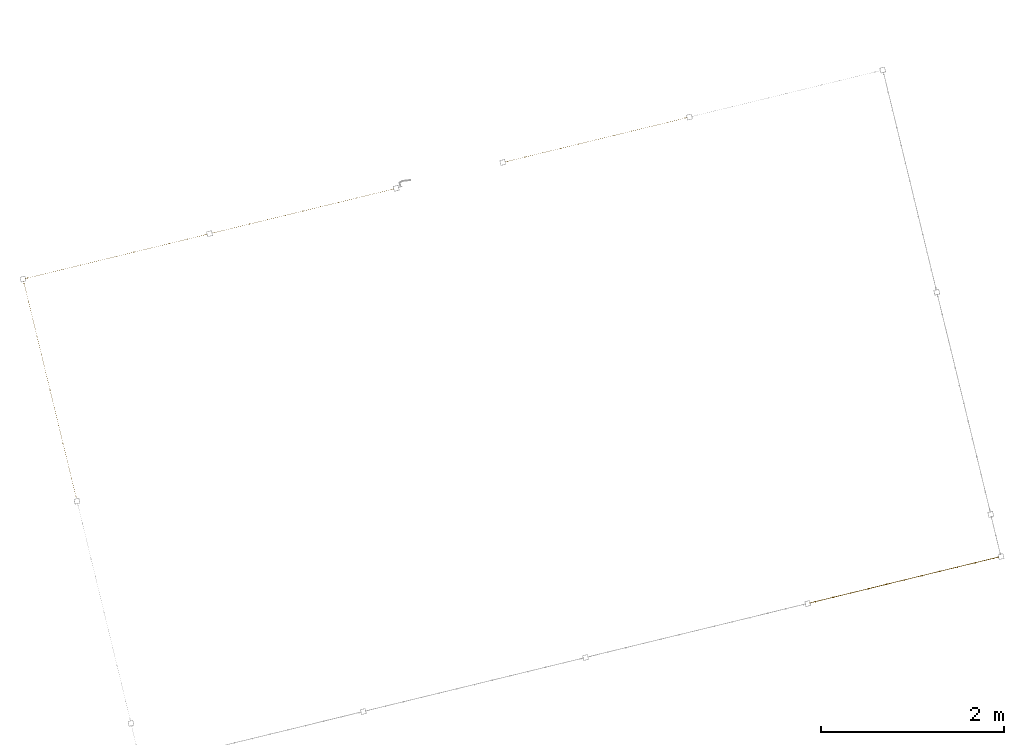
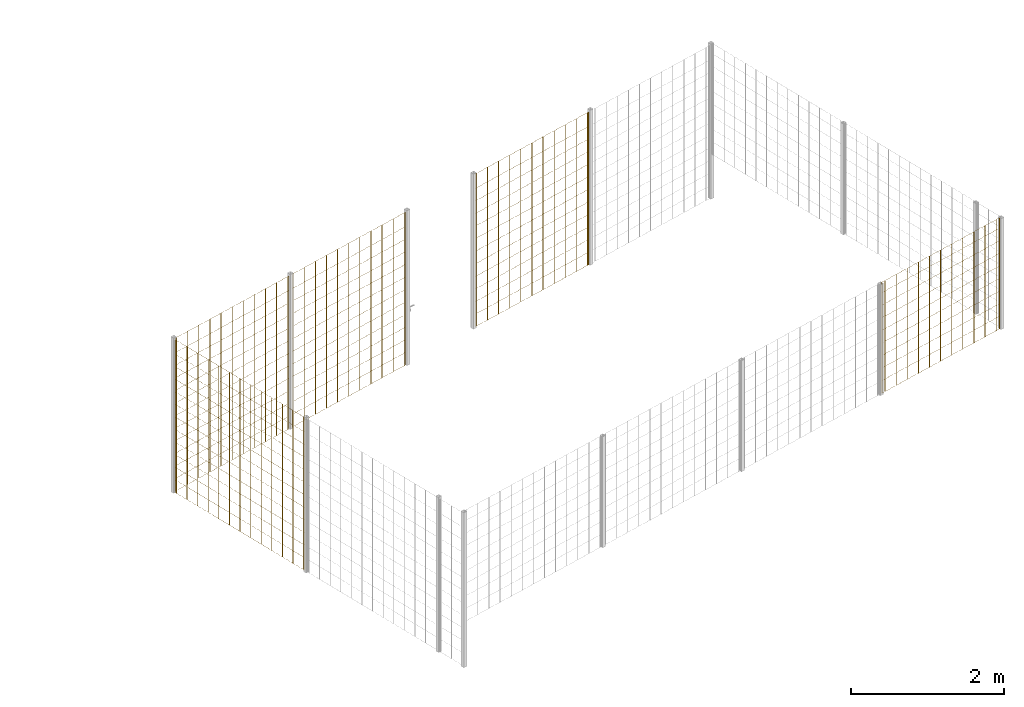
# One storey, part 8 of 10: 5 railings.
"""IFC2X3 building model written with IfcOpenShell, lengths in millimetres."""

from ifc_helpers import new_model, entity, si_unit, converted_unit, derived_unit, direction, frame, frame_2d, origin, origin_2d_with_axis, place, context, subcontext, project, spatial, rectangle, circle, extrude, material, material_list, element, save


model = new_model("IFC2X3")

# Units and contexts
model_context = context("Model", 3, precision=0.01, world=origin(), true_north=direction((6.12303176911189e-17, 1.0)))
body_context = subcontext(model_context, "Body", "Model", "MODEL_VIEW")
ifc_project = project(units=[si_unit("LENGTHUNIT", "METRE", prefix="MILLI"), si_unit("AREAUNIT", "SQUARE_METRE"), si_unit("VOLUMEUNIT", "CUBIC_METRE"), converted_unit("PLANEANGLEUNIT", "DEGREE", entity("IfcRatioMeasure", 0.0174532925199433), si_unit("PLANEANGLEUNIT", "RADIAN"), dimensions=[0, 0, 0, 0, 0, 0, 0]), si_unit("MASSUNIT", "GRAM", prefix="KILO"), derived_unit("MASSDENSITYUNIT", [(si_unit("MASSUNIT", "GRAM", prefix="KILO"), 1), (si_unit("LENGTHUNIT", "METRE"), -3)]), derived_unit("MOMENTOFINERTIAUNIT", [(si_unit("LENGTHUNIT", "METRE"), 4)]), si_unit("TIMEUNIT", "SECOND"), si_unit("FREQUENCYUNIT", "HERTZ"), si_unit("THERMODYNAMICTEMPERATUREUNIT", "DEGREE_CELSIUS"), derived_unit("THERMALTRANSMITTANCEUNIT", [(si_unit("MASSUNIT", "GRAM", prefix="KILO"), 1), (si_unit("THERMODYNAMICTEMPERATUREUNIT", "KELVIN"), -1), (si_unit("TIMEUNIT", "SECOND"), -3)]), derived_unit("VOLUMETRICFLOWRATEUNIT", [(si_unit("LENGTHUNIT", "METRE"), 3), (si_unit("TIMEUNIT", "SECOND"), -1)]), derived_unit("MASSFLOWRATEUNIT", [(si_unit("MASSUNIT", "GRAM", prefix="KILO"), 1), (si_unit("TIMEUNIT", "SECOND"), -1)]), derived_unit("ROTATIONALFREQUENCYUNIT", [(si_unit("TIMEUNIT", "SECOND"), -1)]), si_unit("ELECTRICCURRENTUNIT", "AMPERE"), si_unit("ELECTRICVOLTAGEUNIT", "VOLT"), si_unit("POWERUNIT", "WATT"), si_unit("FORCEUNIT", "NEWTON", prefix="KILO"), si_unit("ILLUMINANCEUNIT", "LUX"), si_unit("LUMINOUSFLUXUNIT", "LUMEN"), si_unit("LUMINOUSINTENSITYUNIT", "CANDELA"), derived_unit("USERDEFINED", [(si_unit("MASSUNIT", "GRAM", prefix="KILO"), -1), (si_unit("LENGTHUNIT", "METRE"), -2), (si_unit("TIMEUNIT", "SECOND"), 3), (si_unit("LUMINOUSFLUXUNIT", "LUMEN"), 1)]), derived_unit("LINEARVELOCITYUNIT", [(si_unit("LENGTHUNIT", "METRE"), 1), (si_unit("TIMEUNIT", "SECOND"), -1)]), si_unit("PRESSUREUNIT", "PASCAL"), derived_unit("USERDEFINED", [(si_unit("LENGTHUNIT", "METRE"), -2), (si_unit("MASSUNIT", "GRAM", prefix="KILO"), 1), (si_unit("TIMEUNIT", "SECOND"), -2)]), derived_unit("LINEARFORCEUNIT", [(si_unit("MASSUNIT", "GRAM", prefix="KILO"), 1), (si_unit("LENGTHUNIT", "METRE"), 1), (si_unit("TIMEUNIT", "SECOND"), -2), (si_unit("LENGTHUNIT", "METRE"), -1)]), derived_unit("PLANARFORCEUNIT", [(si_unit("MASSUNIT", "GRAM", prefix="KILO"), 1), (si_unit("LENGTHUNIT", "METRE"), 1), (si_unit("TIMEUNIT", "SECOND"), -2), (si_unit("LENGTHUNIT", "METRE"), -2)])], contexts=[model_context])

# Site, building, storey
site_placement = place(None, frame((19171.746869958, -72498.5768491146, 0.0), z_axis=(0.0, 0.0, 1.0), x_axis=(0.971695960795463, 0.236234967296933, 0.0)))
site = spatial("IfcSite", under=ifc_project, at=site_placement, CompositionType="ELEMENT")
building_placement = place(site_placement, origin())
building = spatial("IfcBuilding", under=site, at=building_placement, CompositionType="ELEMENT")
storey_placement = place(building_placement, origin())
storey = spatial("IfcBuildingStorey", under=building, at=storey_placement, CompositionType="ELEMENT", Elevation=0.0)

# Railings
ifc_material = material()
ifc_material_list_1 = material_list([ifc_material, ifc_material, ifc_material, ifc_material, ifc_material, ifc_material, ifc_material, ifc_material, ifc_material, ifc_material, ifc_material, ifc_material, ifc_material, ifc_material, ifc_material, ifc_material, ifc_material, ifc_material, ifc_material, ifc_material, ifc_material, ifc_material, ifc_material, ifc_material, ifc_material, ifc_material, ifc_material, ifc_material])
railing_1_placement = place(storey_placement, frame((193.412500000029, 3120.91249999997, 0.0)))
element("IfcRailing", 1, at=railing_1_placement, inside=storey, material=ifc_material_list_1, PredefinedType="NOTDEFINED", context=body_context, shape_type="SweptSolid", body=[
    extrude(circle(Radius=5.0, at=origin_2d_with_axis()), frame((6.58750000000395, 2429.78750000002, 2.0), z_axis=(0.0, 0.0, 1.0), x_axis=(-1.0, 0.0, 0.0)), (0.0, 0.0, 1.0), 2428.0),
    extrude(circle(Radius=5.0, at=origin_2d_with_axis()), frame((6.58750000000361, 2229.78750000002, 2.0), z_axis=(0.0, 0.0, 1.0), x_axis=(-1.0, 0.0, 0.0)), (0.0, 0.0, 1.0), 2428.0),
    extrude(circle(Radius=5.0, at=origin_2d_with_axis()), frame((6.58750000000331, 2029.78750000002, 2.0), z_axis=(0.0, 0.0, 1.0), x_axis=(-1.0, 0.0, 0.0)), (0.0, 0.0, 1.0), 2428.0),
    extrude(circle(Radius=5.0, at=origin_2d_with_axis()), frame((6.58750000000297, 1829.78750000002, 2.0), z_axis=(0.0, 0.0, 1.0), x_axis=(-1.0, 0.0, 0.0)), (0.0, 0.0, 1.0), 2428.0),
    extrude(circle(Radius=5.0, at=origin_2d_with_axis()), frame((6.58750000000266, 1629.78750000002, 2.0), z_axis=(0.0, 0.0, 1.0), x_axis=(-1.0, 0.0, 0.0)), (0.0, 0.0, 1.0), 2428.0),
    extrude(circle(Radius=5.0, at=origin_2d_with_axis()), frame((6.58750000000233, 1429.78750000002, 2.0), z_axis=(0.0, 0.0, 1.0), x_axis=(-1.0, 0.0, 0.0)), (0.0, 0.0, 1.0), 2428.0),
    extrude(circle(Radius=5.0, at=origin_2d_with_axis()), frame((6.58750000000199, 1229.78750000002, 2.0), z_axis=(0.0, 0.0, 1.0), x_axis=(-1.0, 0.0, 0.0)), (0.0, 0.0, 1.0), 2428.0),
    extrude(circle(Radius=5.0, at=origin_2d_with_axis()), frame((6.58750000000168, 1029.78750000002, 2.0), z_axis=(0.0, 0.0, 1.0), x_axis=(-1.0, 0.0, 0.0)), (0.0, 0.0, 1.0), 2428.0),
    extrude(circle(Radius=5.0, at=origin_2d_with_axis()), frame((6.58750000000135, 829.787500000016, 2.0), z_axis=(0.0, 0.0, 1.0), x_axis=(-1.0, 0.0, 0.0)), (0.0, 0.0, 1.0), 2428.0),
    extrude(circle(Radius=5.0, at=origin_2d_with_axis()), frame((6.58750000000104, 629.787500000016, 2.0), z_axis=(0.0, 0.0, 1.0), x_axis=(-1.0, 0.0, 0.0)), (0.0, 0.0, 1.0), 2428.0),
    extrude(circle(Radius=5.0, at=origin_2d_with_axis()), frame((6.5875000000007, 429.787500000016, 2.0), z_axis=(0.0, 0.0, 1.0), x_axis=(-1.0, 0.0, 0.0)), (0.0, 0.0, 1.0), 2428.0),
    extrude(circle(Radius=5.0, at=origin_2d_with_axis()), frame((6.5875000000004, 229.787500000016, 2.0), z_axis=(0.0, 0.0, 1.0), x_axis=(-1.0, 0.0, 0.0)), (0.0, 0.0, 1.0), 2428.0),
    extrude(circle(Radius=5.0, at=origin_2d_with_axis()), frame((6.58750000000006, 29.787500000016, 2.0), z_axis=(0.0, 0.0, 1.0), x_axis=(-1.0, 0.0, 0.0)), (0.0, 0.0, 1.0), 2428.0),
    extrude(circle(Radius=5.0, at=origin_2d_with_axis()), frame((6.58750000000398, 2452.98750000003, 2.0), z_axis=(0.0, 0.0, 1.0), x_axis=(-1.0, 0.0, 0.0)), (0.0, 0.0, 1.0), 2428.0),
    extrude(circle(Radius=5.0, at=origin_2d_with_axis()), frame((6.58750000000003, 6.58750000000013, 2.0), z_axis=(0.0, 0.0, 1.0), x_axis=(-1.0, 0.0, 0.0)), (0.0, 0.0, 1.0), 2428.0),
    extrude(rectangle(XDim=2446.40000000003, YDim=1.99999999999988, at=frame_2d((-5.6843418860808e-13, 1.69309011255336e-14), x_axis=(1.0, 0.0))), frame((7.58750000000196, 1229.78750000002, 0.0), z_axis=(0.0, 0.0, 1.0), x_axis=(0.0, 1.0, 0.0)), (0.0, 0.0, 1.0), 2.00000000000043),
    extrude(rectangle(XDim=2446.40000000003, YDim=1.99999999999988, at=frame_2d((-5.6843418860808e-13, 1.69309011255336e-14), x_axis=(1.0, 0.0))), frame((7.58750000000196, 1229.78750000002, 200.0), z_axis=(0.0, 0.0, 1.0), x_axis=(0.0, 1.0, 0.0)), (0.0, 0.0, 1.0), 2.00000000000043),
    extrude(rectangle(XDim=2446.40000000003, YDim=1.99999999999988, at=frame_2d((-5.6843418860808e-13, 1.69309011255336e-14), x_axis=(1.0, 0.0))), frame((7.58750000000196, 1229.78750000002, 400.0), z_axis=(0.0, 0.0, 1.0), x_axis=(0.0, 1.0, 0.0)), (0.0, 0.0, 1.0), 2.00000000000043),
    extrude(rectangle(XDim=2446.40000000003, YDim=1.99999999999988, at=frame_2d((-5.6843418860808e-13, 1.69309011255336e-14), x_axis=(1.0, 0.0))), frame((7.58750000000196, 1229.78750000002, 600.0), z_axis=(0.0, 0.0, 1.0), x_axis=(0.0, 1.0, 0.0)), (0.0, 0.0, 1.0), 2.00000000000043),
    extrude(rectangle(XDim=2446.40000000003, YDim=1.99999999999988, at=frame_2d((-5.6843418860808e-13, 1.69309011255336e-14), x_axis=(1.0, 0.0))), frame((7.58750000000196, 1229.78750000002, 800.0), z_axis=(0.0, 0.0, 1.0), x_axis=(0.0, 1.0, 0.0)), (0.0, 0.0, 1.0), 2.00000000000036),
    extrude(rectangle(XDim=2446.40000000003, YDim=1.99999999999988, at=frame_2d((-5.6843418860808e-13, 1.69309011255336e-14), x_axis=(1.0, 0.0))), frame((7.58750000000196, 1229.78750000002, 1000.0), z_axis=(0.0, 0.0, 1.0), x_axis=(0.0, 1.0, 0.0)), (0.0, 0.0, 1.0), 2.00000000000036),
    extrude(rectangle(XDim=2446.40000000003, YDim=1.99999999999988, at=frame_2d((-5.6843418860808e-13, 1.69309011255336e-14), x_axis=(1.0, 0.0))), frame((7.58750000000196, 1229.78750000002, 1200.0), z_axis=(0.0, 0.0, 1.0), x_axis=(0.0, 1.0, 0.0)), (0.0, 0.0, 1.0), 2.00000000000036),
    extrude(rectangle(XDim=2446.40000000003, YDim=1.99999999999988, at=frame_2d((-5.6843418860808e-13, 1.69309011255336e-14), x_axis=(1.0, 0.0))), frame((7.58750000000196, 1229.78750000002, 1400.0), z_axis=(0.0, 0.0, 1.0), x_axis=(0.0, 1.0, 0.0)), (0.0, 0.0, 1.0), 2.00000000000036),
    extrude(rectangle(XDim=2446.40000000003, YDim=1.99999999999988, at=frame_2d((-5.6843418860808e-13, 1.69309011255336e-14), x_axis=(1.0, 0.0))), frame((7.58750000000196, 1229.78750000002, 1600.0), z_axis=(0.0, 0.0, 1.0), x_axis=(0.0, 1.0, 0.0)), (0.0, 0.0, 1.0), 2.00000000000036),
    extrude(rectangle(XDim=2446.40000000003, YDim=1.99999999999988, at=frame_2d((-5.6843418860808e-13, 1.69309011255336e-14), x_axis=(1.0, 0.0))), frame((7.58750000000196, 1229.78750000002, 1800.0), z_axis=(0.0, 0.0, 1.0), x_axis=(0.0, 1.0, 0.0)), (0.0, 0.0, 1.0), 2.00000000000036),
    extrude(rectangle(XDim=2446.40000000003, YDim=1.99999999999988, at=frame_2d((-5.6843418860808e-13, 1.69309011255336e-14), x_axis=(1.0, 0.0))), frame((7.58750000000196, 1229.78750000002, 2000.0), z_axis=(0.0, 0.0, 1.0), x_axis=(0.0, 1.0, 0.0)), (0.0, 0.0, 1.0), 2.00000000000036),
    extrude(rectangle(XDim=2446.40000000003, YDim=1.99999999999988, at=frame_2d((-5.6843418860808e-13, 1.69309011255336e-14), x_axis=(1.0, 0.0))), frame((7.58750000000196, 1229.78750000002, 2200.0), z_axis=(0.0, 0.0, 1.0), x_axis=(0.0, 1.0, 0.0)), (0.0, 0.0, 1.0), 2.00000000000036),
    extrude(rectangle(XDim=2446.40000000003, YDim=1.99999999999988, at=frame_2d((-5.6843418860808e-13, 1.69309011255336e-14), x_axis=(1.0, 0.0))), frame((7.58750000000196, 1229.78750000002, 2430.0), z_axis=(0.0, 0.0, 1.0), x_axis=(0.0, 1.0, 0.0)), (0.0, 0.0, 1.0), 2.00000000000036),
])
ifc_material_list_2 = material_list([ifc_material, ifc_material, ifc_material, ifc_material, ifc_material, ifc_material, ifc_material, ifc_material, ifc_material, ifc_material, ifc_material, ifc_material, ifc_material, ifc_material, ifc_material, ifc_material, ifc_material, ifc_material, ifc_material, ifc_material, ifc_material, ifc_material, ifc_material, ifc_material, ifc_material, ifc_material])
railing_2_placement = place(storey_placement, frame((224.412500000031, 5593.41249999999, 0.0)))
element("IfcRailing", 2, at=railing_2_placement, inside=storey, material=ifc_material_list_2, PredefinedType="NOTDEFINED", context=body_context, shape_type="SweptSolid", body=[
    extrude(circle(Radius=5.0, at=origin_2d_with_axis()), frame((2025.58749999999, 6.58749999999959, 2.0), z_axis=(0.0, 0.0, 1.0), x_axis=(0.0, 1.0, 0.0)), (0.0, 0.0, 1.0), 2428.0),
    extrude(circle(Radius=5.0, at=origin_2d_with_axis()), frame((1825.58749999999, 6.58750000000067, 2.0), z_axis=(0.0, 0.0, 1.0), x_axis=(0.0, 1.0, 0.0)), (0.0, 0.0, 1.0), 2428.0),
    extrude(circle(Radius=5.0, at=origin_2d_with_axis()), frame((1625.58749999999, 6.58750000000067, 2.0), z_axis=(0.0, 0.0, 1.0), x_axis=(0.0, 1.0, 0.0)), (0.0, 0.0, 1.0), 2428.0),
    extrude(circle(Radius=5.0, at=origin_2d_with_axis()), frame((1425.58749999999, 6.58750000000175, 2.0), z_axis=(0.0, 0.0, 1.0), x_axis=(0.0, 1.0, 0.0)), (0.0, 0.0, 1.0), 2428.0),
    extrude(circle(Radius=5.0, at=origin_2d_with_axis()), frame((1225.58749999999, 6.58750000000175, 2.0), z_axis=(0.0, 0.0, 1.0), x_axis=(0.0, 1.0, 0.0)), (0.0, 0.0, 1.0), 2428.0),
    extrude(circle(Radius=5.0, at=origin_2d_with_axis()), frame((1025.58749999999, 6.58750000000283, 2.0), z_axis=(0.0, 0.0, 1.0), x_axis=(0.0, 1.0, 0.0)), (0.0, 0.0, 1.0), 2428.0),
    extrude(circle(Radius=5.0, at=origin_2d_with_axis()), frame((825.587499999992, 6.58750000000392, 2.0), z_axis=(0.0, 0.0, 1.0), x_axis=(0.0, 1.0, 0.0)), (0.0, 0.0, 1.0), 2428.0),
    extrude(circle(Radius=5.0, at=origin_2d_with_axis()), frame((625.587499999992, 6.58750000000392, 2.0), z_axis=(0.0, 0.0, 1.0), x_axis=(0.0, 1.0, 0.0)), (0.0, 0.0, 1.0), 2428.0),
    extrude(circle(Radius=5.0, at=origin_2d_with_axis()), frame((425.587499999992, 6.587500000005, 2.0), z_axis=(0.0, 0.0, 1.0), x_axis=(0.0, 1.0, 0.0)), (0.0, 0.0, 1.0), 2428.0),
    extrude(circle(Radius=5.0, at=frame_2d((-2.15763227376402e-28, 6.76791955811495e-14), x_axis=(1.0, 0.0))), frame((225.587499999992, 6.587500000005, 2.0), z_axis=(0.0, 0.0, 1.0), x_axis=(0.0, 1.0, 0.0)), (0.0, 0.0, 1.0), 2428.0),
    extrude(circle(Radius=5.0, at=frame_2d((-1.07881613688201e-28, 3.38395977905748e-14), x_axis=(1.0, 0.0))), frame((25.5874999999919, 6.58750000000608, 2.0), z_axis=(0.0, 0.0, 1.0), x_axis=(0.0, 1.0, 0.0)), (0.0, 0.0, 1.0), 2428.0),
    extrude(circle(Radius=5.0, at=origin_2d_with_axis()), frame((2044.58749999998, 6.58749999999959, 2.0), z_axis=(0.0, 0.0, 1.0), x_axis=(0.0, 1.0, 0.0)), (0.0, 0.0, 1.0), 2428.0),
    extrude(circle(Radius=5.0, at=frame_2d((-1.07881613688201e-28, 3.38395977905748e-14), x_axis=(1.0, 0.0))), frame((6.58750000000006, 6.58750000000608, 2.0), z_axis=(0.0, 0.0, 1.0), x_axis=(0.0, 1.0, 0.0)), (0.0, 0.0, 1.0), 2428.0),
    extrude(rectangle(XDim=2037.99999999998, YDim=1.99999999999955, at=origin_2d_with_axis()), frame((1025.58749999999, 5.58750000000306, 0.0)), (0.0, 0.0, 1.0), 2.00000000000043),
    extrude(rectangle(XDim=2037.99999999998, YDim=1.99999999999955, at=origin_2d_with_axis()), frame((1025.58749999999, 5.58750000000306, 200.0)), (0.0, 0.0, 1.0), 2.00000000000043),
    extrude(rectangle(XDim=2037.99999999998, YDim=1.99999999999955, at=origin_2d_with_axis()), frame((1025.58749999999, 5.58750000000306, 400.0)), (0.0, 0.0, 1.0), 2.00000000000043),
    extrude(rectangle(XDim=2037.99999999998, YDim=1.99999999999955, at=origin_2d_with_axis()), frame((1025.58749999999, 5.58750000000306, 600.0)), (0.0, 0.0, 1.0), 2.00000000000043),
    extrude(rectangle(XDim=2037.99999999998, YDim=1.99999999999955, at=origin_2d_with_axis()), frame((1025.58749999999, 5.58750000000306, 800.0)), (0.0, 0.0, 1.0), 2.00000000000036),
    extrude(rectangle(XDim=2037.99999999998, YDim=1.99999999999955, at=origin_2d_with_axis()), frame((1025.58749999999, 5.58750000000306, 1000.0)), (0.0, 0.0, 1.0), 2.00000000000036),
    extrude(rectangle(XDim=2037.99999999998, YDim=1.99999999999955, at=origin_2d_with_axis()), frame((1025.58749999999, 5.58750000000306, 1200.0)), (0.0, 0.0, 1.0), 2.00000000000036),
    extrude(rectangle(XDim=2037.99999999998, YDim=1.99999999999955, at=origin_2d_with_axis()), frame((1025.58749999999, 5.58750000000306, 1400.0)), (0.0, 0.0, 1.0), 2.00000000000036),
    extrude(rectangle(XDim=2037.99999999998, YDim=1.99999999999955, at=origin_2d_with_axis()), frame((1025.58749999999, 5.58750000000306, 1600.0)), (0.0, 0.0, 1.0), 2.00000000000036),
    extrude(rectangle(XDim=2037.99999999998, YDim=1.99999999999955, at=origin_2d_with_axis()), frame((1025.58749999999, 5.58750000000306, 1800.0)), (0.0, 0.0, 1.0), 2.00000000000036),
    extrude(rectangle(XDim=2037.99999999998, YDim=1.99999999999955, at=origin_2d_with_axis()), frame((1025.58749999999, 5.58750000000306, 2000.0)), (0.0, 0.0, 1.0), 2.00000000000036),
    extrude(rectangle(XDim=2037.99999999998, YDim=1.99999999999955, at=origin_2d_with_axis()), frame((1025.58749999999, 5.58750000000306, 2200.0)), (0.0, 0.0, 1.0), 2.00000000000036),
    extrude(rectangle(XDim=2037.99999999998, YDim=1.99999999999955, at=origin_2d_with_axis()), frame((1025.58749999999, 5.58750000000306, 2430.0)), (0.0, 0.0, 1.0), 2.00000000000036),
])
ifc_material_list_3 = material_list([ifc_material, ifc_material, ifc_material, ifc_material, ifc_material, ifc_material, ifc_material, ifc_material, ifc_material, ifc_material, ifc_material, ifc_material, ifc_material, ifc_material, ifc_material, ifc_material, ifc_material, ifc_material, ifc_material, ifc_material, ifc_material, ifc_material, ifc_material, ifc_material, ifc_material, ifc_material])
railing_3_placement = place(storey_placement, frame((2324.41250000003, 5593.41249999999, 0.0)))
element("IfcRailing", 3, at=railing_3_placement, inside=storey, material=ifc_material_list_3, PredefinedType="NOTDEFINED", context=body_context, shape_type="SweptSolid", body=[
    extrude(circle(Radius=5.0, at=origin_2d_with_axis()), frame((2025.58749999999, 6.58749999999959, 2.0), z_axis=(0.0, 0.0, 1.0), x_axis=(0.0, 1.0, 0.0)), (0.0, 0.0, 1.0), 2428.0),
    extrude(circle(Radius=5.0, at=origin_2d_with_axis()), frame((1825.58749999999, 6.58750000000067, 2.0), z_axis=(0.0, 0.0, 1.0), x_axis=(0.0, 1.0, 0.0)), (0.0, 0.0, 1.0), 2428.0),
    extrude(circle(Radius=5.0, at=origin_2d_with_axis()), frame((1625.58749999999, 6.58750000000067, 2.0), z_axis=(0.0, 0.0, 1.0), x_axis=(0.0, 1.0, 0.0)), (0.0, 0.0, 1.0), 2428.0),
    extrude(circle(Radius=5.0, at=origin_2d_with_axis()), frame((1425.58749999999, 6.58750000000175, 2.0), z_axis=(0.0, 0.0, 1.0), x_axis=(0.0, 1.0, 0.0)), (0.0, 0.0, 1.0), 2428.0),
    extrude(circle(Radius=5.0, at=origin_2d_with_axis()), frame((1225.58749999999, 6.58750000000175, 2.0), z_axis=(0.0, 0.0, 1.0), x_axis=(0.0, 1.0, 0.0)), (0.0, 0.0, 1.0), 2428.0),
    extrude(circle(Radius=5.0, at=origin_2d_with_axis()), frame((1025.58749999999, 6.58750000000283, 2.0), z_axis=(0.0, 0.0, 1.0), x_axis=(0.0, 1.0, 0.0)), (0.0, 0.0, 1.0), 2428.0),
    extrude(circle(Radius=5.0, at=origin_2d_with_axis()), frame((825.587499999991, 6.58750000000392, 2.0), z_axis=(0.0, 0.0, 1.0), x_axis=(0.0, 1.0, 0.0)), (0.0, 0.0, 1.0), 2428.0),
    extrude(circle(Radius=5.0, at=origin_2d_with_axis()), frame((625.587499999991, 6.58750000000392, 2.0), z_axis=(0.0, 0.0, 1.0), x_axis=(0.0, 1.0, 0.0)), (0.0, 0.0, 1.0), 2428.0),
    extrude(circle(Radius=5.0, at=origin_2d_with_axis()), frame((425.587499999991, 6.587500000005, 2.0), z_axis=(0.0, 0.0, 1.0), x_axis=(0.0, 1.0, 0.0)), (0.0, 0.0, 1.0), 2428.0),
    extrude(circle(Radius=5.0, at=origin_2d_with_axis()), frame((225.587499999991, 6.587500000005, 2.0), z_axis=(0.0, 0.0, 1.0), x_axis=(0.0, 1.0, 0.0)), (0.0, 0.0, 1.0), 2428.0),
    extrude(circle(Radius=5.0, at=origin_2d_with_axis()), frame((25.5874999999915, 6.58750000000608, 2.0), z_axis=(0.0, 0.0, 1.0), x_axis=(0.0, 1.0, 0.0)), (0.0, 0.0, 1.0), 2428.0),
    extrude(circle(Radius=5.0, at=origin_2d_with_axis()), frame((2044.58749999998, 6.58749999999959, 2.0), z_axis=(0.0, 0.0, 1.0), x_axis=(0.0, 1.0, 0.0)), (0.0, 0.0, 1.0), 2428.0),
    extrude(circle(Radius=5.0, at=origin_2d_with_axis()), frame((6.58749999999986, 6.58750000000608, 2.0), z_axis=(0.0, 0.0, 1.0), x_axis=(0.0, 1.0, 0.0)), (0.0, 0.0, 1.0), 2428.0),
    extrude(rectangle(XDim=2037.99999999998, YDim=1.99999999999955, at=frame_2d((2.8421709430404e-13, 0.0), x_axis=(1.0, 0.0))), frame((1025.58749999999, 5.58750000000306, 0.0)), (0.0, 0.0, 1.0), 2.00000000000043),
    extrude(rectangle(XDim=2037.99999999998, YDim=1.99999999999955, at=frame_2d((2.8421709430404e-13, 0.0), x_axis=(1.0, 0.0))), frame((1025.58749999999, 5.58750000000306, 200.0)), (0.0, 0.0, 1.0), 2.00000000000043),
    extrude(rectangle(XDim=2037.99999999998, YDim=1.99999999999955, at=frame_2d((2.8421709430404e-13, 0.0), x_axis=(1.0, 0.0))), frame((1025.58749999999, 5.58750000000306, 400.0)), (0.0, 0.0, 1.0), 2.00000000000043),
    extrude(rectangle(XDim=2037.99999999998, YDim=1.99999999999955, at=frame_2d((2.8421709430404e-13, 0.0), x_axis=(1.0, 0.0))), frame((1025.58749999999, 5.58750000000306, 600.0)), (0.0, 0.0, 1.0), 2.00000000000043),
    extrude(rectangle(XDim=2037.99999999998, YDim=1.99999999999955, at=frame_2d((2.8421709430404e-13, 0.0), x_axis=(1.0, 0.0))), frame((1025.58749999999, 5.58750000000306, 800.0)), (0.0, 0.0, 1.0), 2.00000000000036),
    extrude(rectangle(XDim=2037.99999999998, YDim=1.99999999999955, at=frame_2d((2.8421709430404e-13, 0.0), x_axis=(1.0, 0.0))), frame((1025.58749999999, 5.58750000000306, 1000.0)), (0.0, 0.0, 1.0), 2.00000000000036),
    extrude(rectangle(XDim=2037.99999999998, YDim=1.99999999999955, at=frame_2d((2.8421709430404e-13, 0.0), x_axis=(1.0, 0.0))), frame((1025.58749999999, 5.58750000000306, 1200.0)), (0.0, 0.0, 1.0), 2.00000000000036),
    extrude(rectangle(XDim=2037.99999999998, YDim=1.99999999999955, at=frame_2d((2.8421709430404e-13, 0.0), x_axis=(1.0, 0.0))), frame((1025.58749999999, 5.58750000000306, 1400.0)), (0.0, 0.0, 1.0), 2.00000000000036),
    extrude(rectangle(XDim=2037.99999999998, YDim=1.99999999999955, at=frame_2d((2.8421709430404e-13, 0.0), x_axis=(1.0, 0.0))), frame((1025.58749999999, 5.58750000000306, 1600.0)), (0.0, 0.0, 1.0), 2.00000000000036),
    extrude(rectangle(XDim=2037.99999999998, YDim=1.99999999999955, at=frame_2d((2.8421709430404e-13, 0.0), x_axis=(1.0, 0.0))), frame((1025.58749999999, 5.58750000000306, 1800.0)), (0.0, 0.0, 1.0), 2.00000000000036),
    extrude(rectangle(XDim=2037.99999999998, YDim=1.99999999999955, at=frame_2d((2.8421709430404e-13, 0.0), x_axis=(1.0, 0.0))), frame((1025.58749999999, 5.58750000000306, 2000.0)), (0.0, 0.0, 1.0), 2.00000000000036),
    extrude(rectangle(XDim=2037.99999999998, YDim=1.99999999999955, at=frame_2d((2.8421709430404e-13, 0.0), x_axis=(1.0, 0.0))), frame((1025.58749999999, 5.58750000000306, 2200.0)), (0.0, 0.0, 1.0), 2.00000000000036),
    extrude(rectangle(XDim=2037.99999999998, YDim=1.99999999999955, at=frame_2d((2.8421709430404e-13, 0.0), x_axis=(1.0, 0.0))), frame((1025.58749999999, 5.58750000000306, 2430.0)), (0.0, 0.0, 1.0), 2.00000000000036),
])
ifc_material_list_4 = material_list([ifc_material, ifc_material, ifc_material, ifc_material, ifc_material, ifc_material, ifc_material, ifc_material, ifc_material, ifc_material, ifc_material, ifc_material, ifc_material, ifc_material, ifc_material, ifc_material, ifc_material, ifc_material, ifc_material, ifc_material, ifc_material, ifc_material, ifc_material, ifc_material, ifc_material, ifc_material])
railing_4_placement = place(storey_placement, frame((5624.41250000003, 5593.41249999997, 0.0)))
element("IfcRailing", 4, at=railing_4_placement, inside=storey, material=ifc_material_list_4, PredefinedType="NOTDEFINED", context=body_context, shape_type="SweptSolid", body=[
    extrude(circle(Radius=5.0, at=origin_2d_with_axis()), frame((2025.58749999999, 6.58749999999959, 2.0), z_axis=(0.0, 0.0, 1.0), x_axis=(0.0, 1.0, 0.0)), (0.0, 0.0, 1.0), 2428.0),
    extrude(circle(Radius=5.0, at=origin_2d_with_axis()), frame((1825.58749999999, 6.58750000000067, 2.0), z_axis=(0.0, 0.0, 1.0), x_axis=(0.0, 1.0, 0.0)), (0.0, 0.0, 1.0), 2428.0),
    extrude(circle(Radius=5.0, at=origin_2d_with_axis()), frame((1625.58749999999, 6.58750000000067, 2.0), z_axis=(0.0, 0.0, 1.0), x_axis=(0.0, 1.0, 0.0)), (0.0, 0.0, 1.0), 2428.0),
    extrude(circle(Radius=5.0, at=origin_2d_with_axis()), frame((1425.58749999999, 6.58750000000175, 2.0), z_axis=(0.0, 0.0, 1.0), x_axis=(0.0, 1.0, 0.0)), (0.0, 0.0, 1.0), 2428.0),
    extrude(circle(Radius=5.0, at=origin_2d_with_axis()), frame((1225.58749999999, 6.58750000000175, 2.0), z_axis=(0.0, 0.0, 1.0), x_axis=(0.0, 1.0, 0.0)), (0.0, 0.0, 1.0), 2428.0),
    extrude(circle(Radius=5.0, at=origin_2d_with_axis()), frame((1025.58749999999, 6.58750000000283, 2.0), z_axis=(0.0, 0.0, 1.0), x_axis=(0.0, 1.0, 0.0)), (0.0, 0.0, 1.0), 2428.0),
    extrude(circle(Radius=5.0, at=origin_2d_with_axis()), frame((825.587499999991, 6.58750000000392, 2.0), z_axis=(0.0, 0.0, 1.0), x_axis=(0.0, 1.0, 0.0)), (0.0, 0.0, 1.0), 2428.0),
    extrude(circle(Radius=5.0, at=origin_2d_with_axis()), frame((625.587499999991, 6.58750000000392, 2.0), z_axis=(0.0, 0.0, 1.0), x_axis=(0.0, 1.0, 0.0)), (0.0, 0.0, 1.0), 2428.0),
    extrude(circle(Radius=5.0, at=origin_2d_with_axis()), frame((425.587499999991, 6.587500000005, 2.0), z_axis=(0.0, 0.0, 1.0), x_axis=(0.0, 1.0, 0.0)), (0.0, 0.0, 1.0), 2428.0),
    extrude(circle(Radius=5.0, at=origin_2d_with_axis()), frame((225.587499999991, 6.587500000005, 2.0), z_axis=(0.0, 0.0, 1.0), x_axis=(0.0, 1.0, 0.0)), (0.0, 0.0, 1.0), 2428.0),
    extrude(circle(Radius=5.0, at=origin_2d_with_axis()), frame((25.5874999999909, 6.58750000000608, 2.0), z_axis=(0.0, 0.0, 1.0), x_axis=(0.0, 1.0, 0.0)), (0.0, 0.0, 1.0), 2428.0),
    extrude(circle(Radius=5.0, at=origin_2d_with_axis()), frame((2044.58749999998, 6.58749999999959, 2.0), z_axis=(0.0, 0.0, 1.0), x_axis=(0.0, 1.0, 0.0)), (0.0, 0.0, 1.0), 2428.0),
    extrude(circle(Radius=5.0, at=origin_2d_with_axis()), frame((6.58749999999959, 6.58750000000608, 2.0), z_axis=(0.0, 0.0, 1.0), x_axis=(0.0, 1.0, 0.0)), (0.0, 0.0, 1.0), 2428.0),
    extrude(rectangle(XDim=2037.99999999998, YDim=1.99999999999955, at=frame_2d((5.6843418860808e-13, 0.0), x_axis=(1.0, 0.0))), frame((1025.58749999999, 5.58750000000306, 0.0)), (0.0, 0.0, 1.0), 2.00000000000043),
    extrude(rectangle(XDim=2037.99999999998, YDim=1.99999999999955, at=frame_2d((5.6843418860808e-13, 0.0), x_axis=(1.0, 0.0))), frame((1025.58749999999, 5.58750000000306, 200.0)), (0.0, 0.0, 1.0), 2.00000000000043),
    extrude(rectangle(XDim=2037.99999999998, YDim=1.99999999999955, at=frame_2d((5.6843418860808e-13, 0.0), x_axis=(1.0, 0.0))), frame((1025.58749999999, 5.58750000000306, 400.0)), (0.0, 0.0, 1.0), 2.00000000000043),
    extrude(rectangle(XDim=2037.99999999998, YDim=1.99999999999955, at=frame_2d((5.6843418860808e-13, 0.0), x_axis=(1.0, 0.0))), frame((1025.58749999999, 5.58750000000306, 600.0)), (0.0, 0.0, 1.0), 2.00000000000043),
    extrude(rectangle(XDim=2037.99999999998, YDim=1.99999999999955, at=frame_2d((5.6843418860808e-13, 0.0), x_axis=(1.0, 0.0))), frame((1025.58749999999, 5.58750000000306, 800.0)), (0.0, 0.0, 1.0), 2.00000000000036),
    extrude(rectangle(XDim=2037.99999999998, YDim=1.99999999999955, at=frame_2d((5.6843418860808e-13, 0.0), x_axis=(1.0, 0.0))), frame((1025.58749999999, 5.58750000000306, 1000.0)), (0.0, 0.0, 1.0), 2.00000000000036),
    extrude(rectangle(XDim=2037.99999999998, YDim=1.99999999999955, at=frame_2d((5.6843418860808e-13, 0.0), x_axis=(1.0, 0.0))), frame((1025.58749999999, 5.58750000000306, 1200.0)), (0.0, 0.0, 1.0), 2.00000000000036),
    extrude(rectangle(XDim=2037.99999999998, YDim=1.99999999999955, at=frame_2d((5.6843418860808e-13, 0.0), x_axis=(1.0, 0.0))), frame((1025.58749999999, 5.58750000000306, 1400.0)), (0.0, 0.0, 1.0), 2.00000000000036),
    extrude(rectangle(XDim=2037.99999999998, YDim=1.99999999999955, at=frame_2d((5.6843418860808e-13, 0.0), x_axis=(1.0, 0.0))), frame((1025.58749999999, 5.58750000000306, 1600.0)), (0.0, 0.0, 1.0), 2.00000000000036),
    extrude(rectangle(XDim=2037.99999999998, YDim=1.99999999999955, at=frame_2d((5.6843418860808e-13, 0.0), x_axis=(1.0, 0.0))), frame((1025.58749999999, 5.58750000000306, 1800.0)), (0.0, 0.0, 1.0), 2.00000000000036),
    extrude(rectangle(XDim=2037.99999999998, YDim=1.99999999999955, at=frame_2d((5.6843418860808e-13, 0.0), x_axis=(1.0, 0.0))), frame((1025.58749999999, 5.58750000000306, 2000.0)), (0.0, 0.0, 1.0), 2.00000000000036),
    extrude(rectangle(XDim=2037.99999999998, YDim=1.99999999999955, at=frame_2d((5.6843418860808e-13, 0.0), x_axis=(1.0, 0.0))), frame((1025.58749999999, 5.58750000000306, 2200.0)), (0.0, 0.0, 1.0), 2.00000000000036),
    extrude(rectangle(XDim=2037.99999999998, YDim=1.99999999999955, at=frame_2d((5.6843418860808e-13, 0.0), x_axis=(1.0, 0.0))), frame((1025.58749999999, 5.58750000000306, 2430.0)), (0.0, 0.0, 1.0), 2.00000000000036),
])
ifc_material_list_5 = material_list([ifc_material, ifc_material, ifc_material, ifc_material, ifc_material, ifc_material, ifc_material, ifc_material, ifc_material, ifc_material, ifc_material, ifc_material, ifc_material, ifc_material, ifc_material, ifc_material, ifc_material, ifc_material, ifc_material, ifc_material, ifc_material, ifc_material, ifc_material])
railing_5_placement = place(storey_placement, frame((7720.91250000003, 118.412499999966, 700.0)))
element("IfcRailing", 5, at=railing_5_placement, inside=storey, material=ifc_material_list_5, PredefinedType="NOTDEFINED", context=body_context, shape_type="SweptSolid", body=[
    extrude(circle(Radius=5.0, at=origin_2d_with_axis()), frame((64.8374999999896, 6.58750000000664, 2.0), z_axis=(0.0, 0.0, 1.0), x_axis=(0.0, -1.0, 0.0)), (0.0, 0.0, 1.0), 1763.0),
    extrude(circle(Radius=5.0, at=origin_2d_with_axis()), frame((264.83749999999, 6.587500000006, 2.0), z_axis=(0.0, 0.0, 1.0), x_axis=(0.0, -1.0, 0.0)), (0.0, 0.0, 1.0), 1763.0),
    extrude(circle(Radius=5.0, at=origin_2d_with_axis()), frame((464.83749999999, 6.58750000000536, 2.0), z_axis=(0.0, 0.0, 1.0), x_axis=(0.0, -1.0, 0.0)), (0.0, 0.0, 1.0), 1763.0),
    extrude(circle(Radius=5.0, at=origin_2d_with_axis()), frame((664.83749999999, 6.5875000000047, 2.0), z_axis=(0.0, 0.0, 1.0), x_axis=(0.0, -1.0, 0.0)), (0.0, 0.0, 1.0), 1763.0),
    extrude(circle(Radius=5.0, at=origin_2d_with_axis()), frame((864.83749999999, 6.58750000000405, 2.0), z_axis=(0.0, 0.0, 1.0), x_axis=(0.0, -1.0, 0.0)), (0.0, 0.0, 1.0), 1763.0),
    extrude(circle(Radius=5.0, at=origin_2d_with_axis()), frame((1064.83749999999, 6.58750000000341, 2.0), z_axis=(0.0, 0.0, 1.0), x_axis=(0.0, -1.0, 0.0)), (0.0, 0.0, 1.0), 1763.0),
    extrude(circle(Radius=5.0, at=origin_2d_with_axis()), frame((1264.83749999999, 6.58750000000277, 2.0), z_axis=(0.0, 0.0, 1.0), x_axis=(0.0, -1.0, 0.0)), (0.0, 0.0, 1.0), 1763.0),
    extrude(circle(Radius=5.0, at=origin_2d_with_axis()), frame((1464.83749999999, 6.58750000000212, 2.0), z_axis=(0.0, 0.0, 1.0), x_axis=(0.0, -1.0, 0.0)), (0.0, 0.0, 1.0), 1763.0),
    extrude(circle(Radius=5.0, at=origin_2d_with_axis()), frame((1664.83749999999, 6.58750000000146, 2.0), z_axis=(0.0, 0.0, 1.0), x_axis=(0.0, -1.0, 0.0)), (0.0, 0.0, 1.0), 1763.0),
    extrude(circle(Radius=5.0, at=origin_2d_with_axis()), frame((1864.83749999999, 6.58750000000082, 2.0), z_axis=(0.0, 0.0, 1.0), x_axis=(0.0, -1.0, 0.0)), (0.0, 0.0, 1.0), 1763.0),
    extrude(circle(Radius=5.0, at=origin_2d_with_axis()), frame((2064.83749999999, 6.58750000000018, 2.0), z_axis=(0.0, 0.0, 1.0), x_axis=(0.0, -1.0, 0.0)), (0.0, 0.0, 1.0), 1763.0),
    extrude(circle(Radius=5.0, at=origin_2d_with_axis()), frame((6.58749999999959, 6.58750000000683, 2.0), z_axis=(0.0, 0.0, 1.0), x_axis=(0.0, -1.0, 0.0)), (0.0, 0.0, 1.0), 1763.0),
    extrude(circle(Radius=5.0, at=origin_2d_with_axis()), frame((2123.08749999998, 6.58749999999999, 2.0), z_axis=(0.0, 0.0, 1.0), x_axis=(0.0, -1.0, 0.0)), (0.0, 0.0, 1.0), 1763.0),
    extrude(rectangle(XDim=2116.49999999998, YDim=1.99999999999988, at=frame_2d((-5.6843418860808e-13, 0.0), x_axis=(1.0, 0.0))), frame((1064.83749999999, 7.58750000000335, 0.0), z_axis=(0.0, 0.0, 1.0), x_axis=(-1.0, 0.0, 0.0)), (0.0, 0.0, 1.0), 2.00000000000036),
    extrude(rectangle(XDim=2116.49999999998, YDim=1.99999999999988, at=frame_2d((-5.6843418860808e-13, 0.0), x_axis=(1.0, 0.0))), frame((1064.83749999999, 7.58750000000335, 200.0), z_axis=(0.0, 0.0, 1.0), x_axis=(-1.0, 0.0, 0.0)), (0.0, 0.0, 1.0), 2.00000000000036),
    extrude(rectangle(XDim=2116.49999999998, YDim=1.99999999999988, at=frame_2d((-5.6843418860808e-13, 0.0), x_axis=(1.0, 0.0))), frame((1064.83749999999, 7.58750000000335, 400.0), z_axis=(0.0, 0.0, 1.0), x_axis=(-1.0, 0.0, 0.0)), (0.0, 0.0, 1.0), 2.00000000000036),
    extrude(rectangle(XDim=2116.49999999998, YDim=1.99999999999988, at=frame_2d((-5.6843418860808e-13, 0.0), x_axis=(1.0, 0.0))), frame((1064.83749999999, 7.58750000000335, 600.0), z_axis=(0.0, 0.0, 1.0), x_axis=(-1.0, 0.0, 0.0)), (0.0, 0.0, 1.0), 2.00000000000036),
    extrude(rectangle(XDim=2116.49999999998, YDim=1.99999999999988, at=frame_2d((-5.6843418860808e-13, 0.0), x_axis=(1.0, 0.0))), frame((1064.83749999999, 7.58750000000335, 800.0), z_axis=(0.0, 0.0, 1.0), x_axis=(-1.0, 0.0, 0.0)), (0.0, 0.0, 1.0), 2.00000000000036),
    extrude(rectangle(XDim=2116.49999999998, YDim=1.99999999999988, at=frame_2d((-5.6843418860808e-13, 0.0), x_axis=(1.0, 0.0))), frame((1064.83749999999, 7.58750000000335, 1000.0), z_axis=(0.0, 0.0, 1.0), x_axis=(-1.0, 0.0, 0.0)), (0.0, 0.0, 1.0), 2.00000000000036),
    extrude(rectangle(XDim=2116.49999999998, YDim=1.99999999999988, at=frame_2d((-5.6843418860808e-13, 0.0), x_axis=(1.0, 0.0))), frame((1064.83749999999, 7.58750000000335, 1200.0), z_axis=(0.0, 0.0, 1.0), x_axis=(-1.0, 0.0, 0.0)), (0.0, 0.0, 1.0), 2.00000000000036),
    extrude(rectangle(XDim=2116.49999999998, YDim=1.99999999999988, at=frame_2d((-5.6843418860808e-13, 0.0), x_axis=(1.0, 0.0))), frame((1064.83749999999, 7.58750000000335, 1400.0), z_axis=(0.0, 0.0, 1.0), x_axis=(-1.0, 0.0, 0.0)), (0.0, 0.0, 1.0), 2.00000000000036),
    extrude(rectangle(XDim=2116.49999999998, YDim=1.99999999999988, at=frame_2d((-5.6843418860808e-13, 0.0), x_axis=(1.0, 0.0))), frame((1064.83749999999, 7.58750000000335, 1600.0), z_axis=(0.0, 0.0, 1.0), x_axis=(-1.0, 0.0, 0.0)), (0.0, 0.0, 1.0), 2.00000000000036),
    extrude(rectangle(XDim=2116.49999999998, YDim=1.99999999999988, at=frame_2d((-5.6843418860808e-13, 0.0), x_axis=(1.0, 0.0))), frame((1064.83749999999, 7.58750000000335, 1765.0), z_axis=(0.0, 0.0, 1.0), x_axis=(-1.0, 0.0, 0.0)), (0.0, 0.0, 1.0), 2.00000000000063),
])

save(model, "model.ifc")
